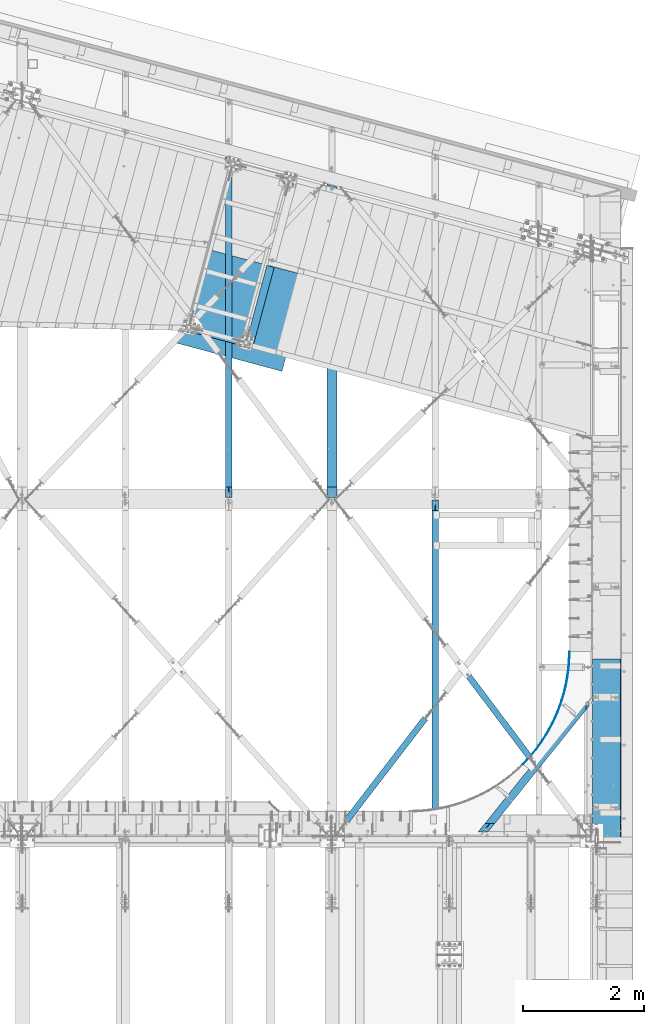
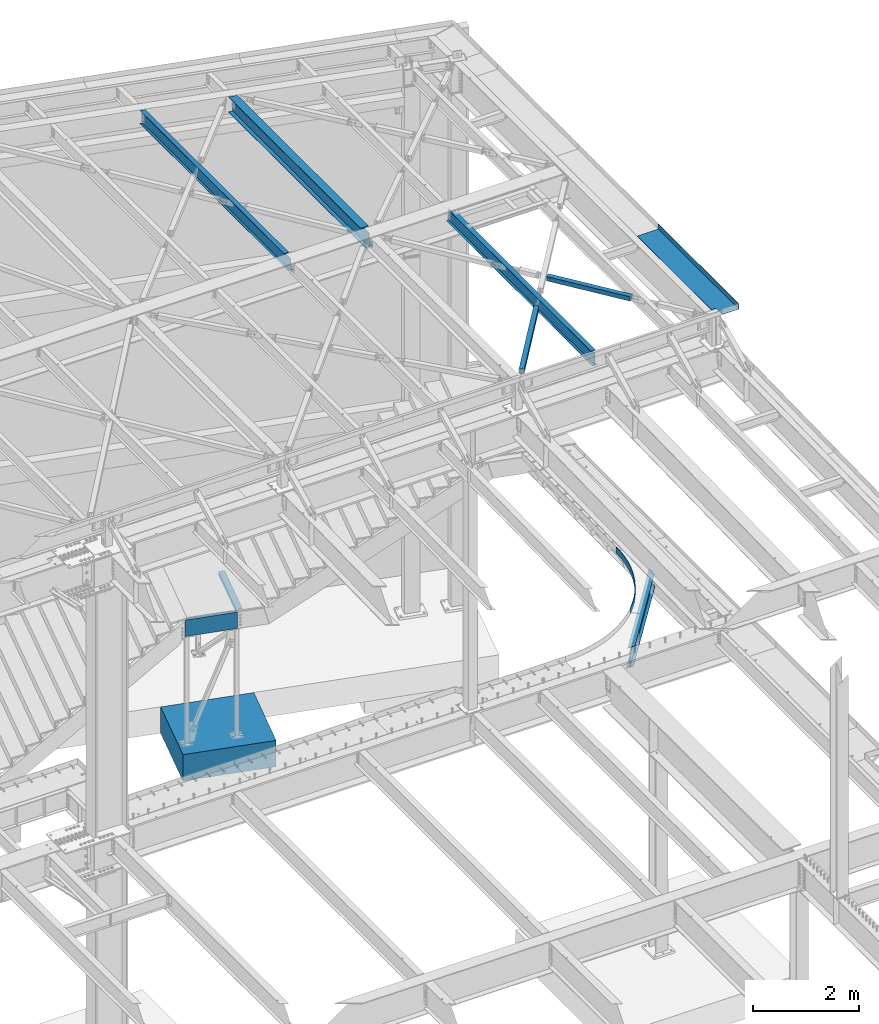
# One storey, part 1168 of 1763: 11 beams, 9 elements without a shape of their own.
"""IFC2X3 building model written with IfcOpenShell, lengths in millimetres."""

from ifc_helpers import new_model, si_unit, frame, origin_with_axes, place, context, subcontext, project, spatial, faceted_brep, material, type_object, element, aggregate, save


model = new_model("IFC2X3")

# Units and contexts
model_context = context("Model", 3, precision=1e-05, world=origin_with_axes())
body_context = subcontext(model_context, "Body", "Model", "MODEL_VIEW")
ifc_project = project(units=[si_unit("LENGTHUNIT", "METRE", prefix="MILLI"), si_unit("AREAUNIT", "SQUARE_METRE"), si_unit("VOLUMEUNIT", "CUBIC_METRE"), si_unit("MASSUNIT", "GRAM", prefix="KILO"), si_unit("TIMEUNIT", "SECOND"), si_unit("PLANEANGLEUNIT", "RADIAN"), si_unit("SOLIDANGLEUNIT", "STERADIAN"), si_unit("THERMODYNAMICTEMPERATUREUNIT", "DEGREE_CELSIUS"), si_unit("LUMINOUSINTENSITYUNIT", "LUMEN")], contexts=[model_context])

# Site, building, storey
site_placement = place(None, origin_with_axes())
site = spatial("IfcSite", under=ifc_project, at=site_placement, CompositionType="ELEMENT")
building_placement = place(site_placement, origin_with_axes())
building = spatial("IfcBuilding", under=site, at=building_placement, Name="Undefined", CompositionType="ELEMENT")
storey_placement = place(building_placement, origin_with_axes())
storey = spatial("IfcBuildingStorey", under=building, at=storey_placement, Name="Undefined", CompositionType="ELEMENT", Elevation=0.0)

# Assembly, beam
assembly_1_placement = place(storey_placement, origin_with_axes())
assembly_1 = element("IfcElementAssembly", 1, at=assembly_1_placement, inside=storey, Name="FRAME", AssemblyPlace="NOTDEFINED", PredefinedType="RIGID_FRAME")
ifc_material_1 = material(Name="STEEL/A36")
beam_type_1 = type_object("IfcBeamType", Name="L5X3X1/4", PredefinedType="NOTDEFINED")
beam_1_placement = place(assembly_1_placement, frame((-27333.7089547892, 60296.3078394912, 2590.8), z_axis=(0.965912656072286, -0.258868192019377, 0.0), x_axis=(0.258868192019374, 0.965912656072287, 0.0)))
beam_1 = element("IfcBeam", 2, at=beam_1_placement, type_object=beam_type_1, material=ifc_material_1, Name="ANGLE", ObjectType="L5X3X1/4", context=body_context, shape_type="Brep", body=[
    faceted_brep([(2.03726813197136e-10, 38.0999999999999, -63.5000000001164), (-2.03726813197136e-10, 38.0999999999999, 63.5000000001164), (1302.58050386085, 38.0999999999999, 63.5000000013679), (1302.58050386054, 38.0999999999999, -63.4999999986103), (-2.03726813197136e-10, 31.75, 63.5000000001164), (1302.58050386085, 31.75, 63.5000000013679), (1.81898940354586e-10, 31.75, -57.1500000001106), (1302.58050386055, 31.75, -57.1499999986117), (1.81898940354586e-10, -38.0999999999999, -57.1500000001106), (1302.58050386055, -38.0999999999999, -57.1499999986117), (2.03726813197136e-10, -38.0999999999999, -63.5000000001164), (1302.58050386054, -38.0999999999999, -63.4999999986103)], [[[0, 1, 2, 3]], [[1, 4, 5, 2]], [[4, 6, 7, 5]], [[6, 8, 9, 7]], [[8, 10, 11, 9]], [[10, 0, 3, 11]], [[5, 7, 9, 11, 3, 2]], [[10, 8, 6, 4, 1, 0]]]),
])

assembly_2_placement = place(storey_placement, origin_with_axes())
assembly_2 = element("IfcElementAssembly", 3, at=assembly_2_placement, inside=storey, Name="BEAM", AssemblyPlace="NOTDEFINED", PredefinedType="RIGID_FRAME")
beam_type_2 = type_object("IfcBeamType", PredefinedType="NOTDEFINED")
beam_2_placement = place(assembly_2_placement, frame((-22813.2239876411, 53302.7560028055, 5245.1), z_axis=(0.0, 0.0, 1.0), x_axis=(0.38198610405508, 0.924168067133258, 0.0)))
beam_2 = element("IfcBeam", 4, at=beam_2_placement, type_object=beam_type_2, material=ifc_material_1, Name="PLATE", context=body_context, shape_type="Brep", body=[
    faceted_brep([(1.81687949722254, 4.40231247671181, -76.1999999999998), (1.81687949722254, 4.40231247671181, 76.1999999999998), (98.140663038459, -33.1626768406859, 76.1999999999998), (98.140663038459, -33.1626768406859, -76.1999999999998), (-1.81687949721527, -4.40231247670454, 76.1999999999998), (-1.81687949721527, -4.40231247670454, -76.1999999999998), (94.8542257076115, -42.1027526049293, -76.1999999999998), (94.8542257076115, -42.1027526049293, 76.1999999999998), (195.860644678804, -66.9295968412698, 76.1999999999998), (195.860644678804, -66.9295968412698, -76.1999999999998), (192.926563384462, -75.9914284418919, -76.1999999999998), (192.926563384462, -75.9914284418919, 76.1999999999998), (294.827130759491, -96.8467212177347, 76.1999999999998), (294.827130759491, -96.8467212177347, -76.1999999999998), (292.249900113253, -106.016427166993, -76.1999999999998), (292.249900113253, -106.016427166993, 76.1999999999998), (394.88851814728, -122.868221023593, 76.1999999999998), (394.88851814728, -122.868221023593, -76.1999999999998), (392.672086114333, -132.131754584996, -76.1999999999998), (392.672086114333, -132.131754584996, 76.1999999999998), (495.891526469735, -144.954234876917, 76.1999999999998), (495.891526469735, -144.954234876917, -76.1999999999998), (494.039288321081, -154.297405582867, -76.1999999999998), (494.039288321081, -154.297405582867, 76.1999999999998), (597.681432919831, -163.070930022448, 76.1999999999998), (597.681432919831, -163.070930022448, -76.1999999999998), (596.196226031221, -172.479425412144, -76.1999999999998), (596.196226031221, -172.479425412144, 76.1999999999998), (700.102309270136, -177.190554158813, 76.1999999999998), (700.102309270136, -177.190554158813, -76.1999999999998), (698.986408775563, -186.649961702948, -76.1999999999998), (698.986408775563, -186.649961702948, 76.1999999999998), (802.997260733529, -187.291477951236, 76.1999999999998), (802.997260733529, -187.291477951236, -76.1999999999998), (802.252376040065, -196.787307130056, -76.1999999999998), (802.252376040065, -196.787307130056, 76.1999999999998), (906.208666304636, -193.35822816471, 76.1999999999998), (906.208666304636, -193.35822816471, -76.1999999999998), (905.835938473858, -202.875932665484, -76.1999999999998), (905.835938473858, -202.875932665484, 76.1999999999998), (1009.57842021359, -195.381511366933, 76.1999999999998), (1009.57842021359, -195.381511366933, -76.1999999999998), (1009.5784202136, -204.90651136692, -76.1999999999998), (1009.5784202136, -204.90651136692, 76.1999999999998), (1112.94817412255, -193.358228164492, 76.1999999999998), (1112.94817412255, -193.358228164492, -76.1999999999998), (1113.32090195334, -202.875932665265, -76.1999999999998), (1113.32090195334, -202.875932665265, 76.1999999999998), (1216.15957969364, -187.291477950785, 76.1999999999998), (1216.15957969364, -187.291477950785, -76.1999999999998), (1216.90446438711, -196.787307129605, -76.1999999999998), (1216.90446438711, -196.787307129605, 76.1999999999998), (1319.05453115702, -177.190554158144, 76.1999999999998), (1319.05453115702, -177.190554158144, -76.1999999999998), (1320.17043165161, -186.649961702278, -76.1999999999998), (1320.17043165161, -186.649961702278, 76.1999999999998), (1421.47540750729, -163.070930021553, 76.1999999999998), (1421.47540750729, -163.070930021553, -76.1999999999998), (1422.96061439592, -172.479425411242, -76.1999999999998), (1422.96061439592, -172.479425411242, 76.1999999999998), (1523.26531395734, -144.954234875797, 76.1999999999998), (1523.26531395734, -144.954234875797, -76.1999999999998), (1525.11755210601, -154.297405581747, -76.1999999999998), (1525.11755210601, -154.297405581747, 76.1999999999998), (1624.26832227975, -122.868221022261, 76.1999999999998), (1624.26832227975, -122.868221022261, -76.1999999999998), (1626.48475431271, -132.13175458365, -76.1999999999998), (1626.48475431271, -132.13175458365, 76.1999999999998), (1724.32970966748, -96.8467212161777, 76.1999999999998), (1724.32970966748, -96.8467212161777, -76.1999999999998), (1726.90694031374, -106.016427165436, -76.1999999999998), (1726.90694031374, -106.016427165436, 76.1999999999998), (1823.29619574809, -66.9295968394945, 76.1999999999998), (1823.29619574809, -66.9295968394945, -76.1999999999998), (1826.23027704246, -75.9914284401166, -76.1999999999998), (1826.23027704246, -75.9914284401166, 76.1999999999998), (1921.01617738837, -33.1626768387068, 76.1999999999998), (1921.01617738837, -33.1626768387068, -76.1999999999998), (1924.30261471924, -42.1027526029357, -76.1999999999998), (1924.30261471924, -42.1027526029357, 76.1999999999998), (2017.33996092953, 4.40231247890915, 76.1999999999998), (2017.33996092953, 4.40231247890915, -76.1999999999998), (2020.97371992398, -4.40231247449992, 76.1999999999998), (2020.97371992398, -4.40231247449992, -76.1999999999998)], [[[0, 1, 2, 3]], [[4, 5, 6, 7]], [[5, 4, 1, 0]], [[3, 2, 8, 9]], [[7, 6, 10, 11]], [[9, 8, 12, 13]], [[11, 10, 14, 15]], [[13, 12, 16, 17]], [[15, 14, 18, 19]], [[17, 16, 20, 21]], [[19, 18, 22, 23]], [[21, 20, 24, 25]], [[23, 22, 26, 27]], [[25, 24, 28, 29]], [[27, 26, 30, 31]], [[29, 28, 32, 33]], [[31, 30, 34, 35]], [[33, 32, 36, 37]], [[35, 34, 38, 39]], [[37, 36, 40, 41]], [[39, 38, 42, 43]], [[41, 40, 44, 45]], [[43, 42, 46, 47]], [[45, 44, 48, 49]], [[47, 46, 50, 51]], [[49, 48, 52, 53]], [[51, 50, 54, 55]], [[53, 52, 56, 57]], [[55, 54, 58, 59]], [[57, 56, 60, 61]], [[59, 58, 62, 63]], [[61, 60, 64, 65]], [[63, 62, 66, 67]], [[65, 64, 68, 69]], [[67, 66, 70, 71]], [[69, 68, 72, 73]], [[71, 70, 74, 75]], [[73, 72, 76, 77]], [[75, 74, 78, 79]], [[77, 76, 80, 81]], [[76, 72, 68, 64, 60, 56, 52, 48, 44, 40, 36, 32, 28, 24, 20, 16, 12, 8, 2, 1, 4, 7, 11, 15, 19, 23, 27, 31, 35, 39, 43, 47, 51, 55, 59, 63, 67, 71, 75, 79, 82, 80]], [[79, 78, 83, 82]], [[78, 74, 70, 66, 62, 58, 54, 50, 46, 42, 38, 34, 30, 26, 22, 18, 14, 10, 6, 5, 0, 3, 9, 13, 17, 21, 25, 29, 33, 37, 41, 45, 49, 53, 57, 61, 65, 69, 73, 77, 81, 83]], [[82, 83, 81, 80]]]),
])

assembly_3_placement = place(storey_placement, origin_with_axes())
assembly_3 = element("IfcElementAssembly", 5, at=assembly_3_placement, inside=storey, Name="BEAM", AssemblyPlace="NOTDEFINED", PredefinedType="RIGID_FRAME")
ifc_material_2 = material(Name="STEEL/A992")
beam_type_3 = type_object("IfcBeamType", Name="W14X30", PredefinedType="NOTDEFINED")
beam_3_placement = place(assembly_3_placement, frame((-25976.6096174479, 57702.4500000004, 12269.7875), z_axis=(0.0, 0.0, 1.0), x_axis=(0.0, 1.0, 0.0)))
beam_3 = element("IfcBeam", 6, at=beam_3_placement, type_object=beam_type_3, material=ifc_material_2, Name="BEAM", ObjectType="W14X30", context=body_context, shape_type="Brep", body=[
    faceted_brep([(179.387500190307, -3.17499999999927, 137.852501678466), (179.387500190307, 3.17499999999927, 137.852501678466), (20.6374999995751, 3.17499999999927, 137.852501678466), (20.6374999995751, -3.17499999999927, 137.852501678466), (184.247579708353, -3.17499999999927, 138.819231601054), (184.247579708353, 3.17499999999927, 138.819231601054), (188.367756176507, -3.17499999999927, 141.572245501531), (188.367756176507, 3.17499999999927, 141.572245501531), (191.120770076981, -3.17499999999927, 145.692421969685), (191.120770076981, 3.17499999999927, 145.692421969685), (192.087499999572, -3.17499999999927, 150.552501487731), (192.087499999572, 3.17499999999927, 150.552501487731), (192.087499999572, -85.7249999999985, 176.2125), (192.087499999572, 85.7249999999985, 176.2125), (192.087499999572, 85.7249999999985, 166.6875), (192.087499999572, 3.17499999999927, 166.6875), (192.087499999572, -3.17499999999927, 166.6875), (192.087499999572, -85.7249999999985, 166.6875), (20.6374999995751, -3.17499999999927, -166.6875), (20.6374999995751, -85.7249999999985, -166.6875), (5167.90416276084, -85.7249999999985, -166.6875), (5190.02336859389, -3.17499999999927, -166.6875), (20.6374999995751, -85.7249999999985, -176.2125), (5167.90416276084, -85.7249999999985, -176.2125), (20.6374999995751, 85.7249999999985, -176.2125), (5213.84405179871, 85.7249999999985, -176.2125), (20.6374999995751, 85.7249999999985, -166.6875), (20.6374999995751, 3.17499999999927, -166.6875), (5191.72484596566, 3.17499999999927, -166.6875), (5213.84405179871, 85.7249999999985, -166.6875), (5191.72484596566, 3.17499999999927, 166.6875), (5213.84405179871, 85.7249999999985, 166.6875), (5213.84405179871, 85.7249999999985, 176.2125), (5167.90416276084, -85.7249999999985, 176.2125), (5167.90416276084, -85.7249999999985, 166.6875), (5190.02336859389, -3.17499999999927, 166.6875)], [[[0, 1, 2, 3]], [[4, 5, 1, 0]], [[6, 7, 5, 4]], [[8, 9, 7, 6]], [[10, 11, 9, 8]], [[12, 13, 14, 15, 11, 10, 16, 17]], [[18, 19, 20, 21]], [[19, 22, 23, 20]], [[22, 24, 25, 23]], [[26, 27, 28, 29]], [[24, 26, 29, 25]], [[28, 30, 31, 32, 33, 34, 35, 21, 20, 23, 25, 29]], [[34, 33, 12, 17]], [[35, 34, 17, 16]], [[8, 6, 4, 0, 3, 18, 21, 35, 16, 10]], [[27, 26, 24, 22, 19, 18, 3, 2]], [[30, 28, 27, 2, 1, 5, 7, 9, 11, 15]], [[31, 30, 15, 14]], [[32, 31, 14, 13]], [[33, 32, 13, 12]]]),
])
aggregate(assembly_3, [beam_3])

assembly_4_placement = place(storey_placement, origin_with_axes())
assembly_4 = element("IfcElementAssembly", 7, at=assembly_4_placement, inside=storey, Name="H. BRACE", AssemblyPlace="NOTDEFINED", PredefinedType="RIGID_FRAME")
ifc_material_3 = material()
beam_type_4 = type_object("IfcBeamType", Name="HSS4X4X3/8", PredefinedType="NOTDEFINED")
beam_4_placement = place(assembly_4_placement, frame((-22546.3296174484, 53216.5500898741, 12371.3875), z_axis=(-0.798711499075791, -0.601714169057122, 0.0), x_axis=(-0.601714169057124, 0.798711499075789, 0.0)))
beam_4 = element("IfcBeam", 8, at=beam_4_placement, type_object=beam_type_4, material=ifc_material_3, Name="H. BRACE", ObjectType="HSS4X4X3/8", context=body_context, shape_type="Brep", body=[
    faceted_brep([(2005.41376927734, 6.35000000000218, 50.8000000003503), (1931.32239554346, 6.35000000000218, 50.8000000003321), (1931.3223955434, 6.35000000000218, 41.2750000003598), (2005.41376927731, 6.35000000000218, 41.2750000003707), (1931.32239554346, -6.34999999999854, 50.8000000003321), (1931.3223955434, -6.34999999999854, 41.2750000003598), (2005.41376927734, -6.34999999999854, 50.8000000003503), (2005.41376927731, -6.34999999999854, 41.2750000003707), (2005.41376927707, 6.35000000000218, -41.2749999994394), (1931.32239554294, 6.35000000000218, -41.2749999994539), (1931.32239554289, 6.35000000000218, -50.7999999994336), (2005.41376927704, 6.35000000000218, -50.7999999994154), (1931.32239554294, -6.34999999999854, -41.2749999994539), (1931.32239554289, -6.34999999999854, -50.7999999994336), (2005.41376927707, -6.34999999999854, -41.2749999994394), (2005.41376927704, -6.34999999999854, -50.7999999994154), (281.529879994778, 41.2749999999996, 41.2749999999724), (281.529879994538, 41.2749999999996, -41.2749999998341), (2005.41376927707, 41.2749999999996, -41.2749999994394), (2005.41376927731, 41.2749999999996, 41.2750000003707), (2005.41376927731, -41.2749999999996, 41.2750000003707), (281.529879994778, -41.2749999999996, 41.2749999999724), (281.529879994538, -41.2749999999996, -41.2749999998341), (2005.41376927707, -41.2749999999996, -41.2749999994394), (281.529879994509, -50.7999999999993, -50.7999999998101), (281.529879994807, -50.7999999999993, 50.7999999999593), (281.529879994807, 50.7999999999993, 50.7999999999593), (281.529879994509, 50.7999999999993, -50.7999999998101), (2005.41376927734, 50.7999999999993, 50.8000000003503), (2005.41376927704, 50.7999999999993, -50.7999999994154), (2005.41376927704, -50.7999999999993, -50.7999999994154), (2005.41376927734, -50.7999999999993, 50.8000000003503)], [[[0, 1, 2, 3]], [[4, 5, 2, 1]], [[6, 7, 5, 4]], [[8, 9, 10, 11]], [[12, 13, 10, 9]], [[14, 15, 13, 12]], [[16, 17, 18, 19]], [[20, 21, 16, 19, 3, 2, 5, 7]], [[22, 21, 20, 23]], [[9, 8, 18, 17, 22, 23, 14, 12]], [[24, 25, 26, 27], [16, 21, 22, 17]], [[27, 26, 28, 29]], [[19, 18, 8, 11, 29, 28, 0, 3]], [[30, 24, 27, 29, 11, 10, 13, 15]], [[25, 24, 30, 31]], [[1, 0, 28, 26, 25, 31, 6, 4]], [[31, 30, 15, 14, 23, 20, 7, 6]]]),
])
aggregate(assembly_4, [beam_4])

assembly_5_placement = place(storey_placement, origin_with_axes())
assembly_5 = element("IfcElementAssembly", 9, at=assembly_5_placement, inside=storey, Name="H. BRACE", AssemblyPlace="NOTDEFINED", PredefinedType="RIGID_FRAME")
beam_5_placement = place(assembly_5_placement, frame((-25925.80961641, 52120.8000005081, 12371.3875), z_axis=(0.0, 0.0, 1.0), x_axis=(0.609825086268862, 0.792536033349383, 0.0)))
beam_5 = element("IfcBeam", 10, at=beam_5_placement, type_object=beam_type_4, material=ifc_material_3, Name="H. BRACE", ObjectType="HSS4X4X3/8", context=body_context, shape_type="Brep", body=[
    faceted_brep([(317.876285807837, 41.2749999990847, -41.2749999999996), (317.876285808015, -41.2750000010492, -41.2749999999996), (2442.64763338234, -41.2750000076412, -41.2749999999996), (2442.64763338215, 41.2749999924927, -41.2749999999996), (317.876285808015, -41.2750000010492, 41.2749999999996), (2442.64763338234, -41.2750000076412, 41.2749999999996), (317.876285807837, 41.2749999990847, 41.2749999999996), (2442.64763338215, 41.2749999924927, 41.2749999999996), (317.876285807812, 50.799999999108, -50.7999999999993), (317.876285807812, 50.799999999108, 50.7999999999993), (2442.64763338213, 50.7999999925014, 50.7999999999993), (2442.64763338213, 50.7999999925014, -50.7999999999993), (317.876285808037, -50.8000000010652, 50.7999999999993), (2442.64763338235, -50.8000000076645, 50.7999999999993), (317.876285808037, -50.8000000010652, -50.7999999999993), (2442.64763338235, -50.8000000076645, -50.7999999999993)], [[[0, 1, 2, 3]], [[1, 4, 5, 2]], [[4, 6, 7, 5]], [[6, 0, 3, 7]], [[8, 9, 10, 11]], [[9, 12, 13, 10]], [[12, 14, 15, 13]], [[14, 8, 11, 15]], [[13, 15, 11, 10], [5, 7, 3, 2]], [[14, 12, 9, 8], [6, 4, 1, 0]]]),
])
aggregate(assembly_5, [beam_5])

# Beam
beam_type_5 = type_object("IfcBeamType", Name="W14X22", PredefinedType="NOTDEFINED")
beam_6_placement = place(assembly_2_placement, frame((-23521.3534441522, 52120.8, 5019.675), z_axis=(0.0, 0.0, 1.0), x_axis=(0.626573581392241, 0.779362269487881, 0.0)))
beam_6 = element("IfcBeam", 11, at=beam_6_placement, type_object=beam_type_5, material=ifc_material_2, Name="BEAM", ObjectType="W14X22", context=body_context, shape_type="Brep", body=[
    faceted_brep([(246.983183446751, -3.1750000003376, 104.775000001958), (241.878057887534, 3.17499999968277, 104.775000001958), (75.8689266779074, 3.17499999990105, 104.77500000184), (80.9740522371176, -3.17500000011205, 104.77500000184), (253.219153172682, -3.1750000003376, 105.741729924549), (248.114027613465, 3.17499999968277, 105.741729924549), (258.50575303705, -3.17500000034488, 108.494743825028), (253.400627477837, 3.17499999966822, 108.494743825028), (262.038146133647, -3.17500000035216, 112.61492029318), (256.93302057443, 3.17499999966822, 112.61492029318), (263.278557634738, -3.17500000035216, 117.474999811223), (258.173432075524, 3.17499999966822, 117.474999811223), (311.777250447274, -63.5000000004948, 174.625), (209.674739262988, 63.4999999998035, 174.625), (209.674739262988, 63.4999999998035, 166.6875), (258.173432075524, 3.17499999966822, 166.6875), (263.278557634738, -3.17500000035216, 166.6875), (311.777250447274, -63.5000000004948, 166.6875), (80.9740522371176, -3.17500000011205, -166.6875), (129.472745049654, -63.5000000002547, -166.6875), (2797.13648107973, -63.5000000037326, -166.6875), (2872.17160912068, -3.17500000375003, -166.6875), (129.472745049654, -63.5000000002547, -174.625), (2797.13648107973, -63.5000000037326, -174.625), (27.3702338653675, 63.5000000000437, -174.625), (2955.10517169224, 63.4999999962238, -174.625), (27.3702338653675, 63.5000000000437, -166.6875), (2955.10517169224, 63.4999999962238, -166.6875), (75.8689266779074, 3.17499999990105, -166.6875), (2880.0700436513, 3.17499999624852, -166.6875), (2880.0700436513, 3.17499999624852, 138.112499999998), (2872.17160912068, -3.17500000375003, 138.112499999998), (2826.86400436265, 3.17499999630672, 138.112499999998), (2818.96556983202, -3.17500000368454, 138.112499999998), (2819.10740615553, 3.17499999632855, 139.079229922586), (2811.20897162491, -3.17500000366999, 139.079229922586), (2812.53167971172, 3.17499999633583, 141.832243823064), (2804.63324518109, -3.17500000366272, 141.832243823064), (2808.13791977315, 3.1749999963431, 145.952420291218), (2800.23948524253, -3.17500000365544, 145.952420291218), (2806.59503646096, 3.1749999963431, 150.812499809263), (2798.69660193034, -3.17500000365544, 150.812499809263), (2881.63016450191, 63.4999999963184, 174.625), (2723.66147388939, -63.500000003638, 174.625), (2723.66147388939, -63.500000003638, 166.6875), (2798.69660193034, -3.17500000365544, 166.6875), (2806.59503646096, 3.1749999963431, 166.6875), (2881.63016450191, 63.4999999963184, 166.6875)], [[[0, 1, 2, 3]], [[4, 5, 1, 0]], [[6, 7, 5, 4]], [[8, 9, 7, 6]], [[10, 11, 9, 8]], [[12, 13, 14, 15, 11, 10, 16, 17]], [[18, 19, 20, 21]], [[19, 22, 23, 20]], [[22, 24, 25, 23]], [[24, 26, 27, 25]], [[26, 28, 29, 27]], [[21, 20, 23, 25, 27, 29, 30, 31]], [[30, 32, 33, 31]], [[34, 35, 33, 32]], [[36, 37, 35, 34]], [[38, 39, 37, 36]], [[40, 41, 39, 38]], [[42, 43, 44, 45, 41, 40, 46, 47]], [[44, 43, 12, 17]], [[45, 44, 17, 16]], [[8, 6, 4, 0, 3, 18, 21, 31, 33, 35, 37, 39, 41, 45, 16, 10]], [[28, 26, 24, 22, 19, 18, 3, 2]], [[46, 40, 38, 36, 34, 32, 30, 29, 28, 2, 1, 5, 7, 9, 11, 15]], [[47, 46, 15, 14]], [[42, 47, 14, 13]], [[43, 42, 13, 12]]]),
])

aggregate(assembly_2, [beam_2, beam_6])

# Assembly, beam
assembly_6_placement = place(storey_placement, origin_with_axes())
assembly_6 = element("IfcElementAssembly", 12, at=assembly_6_placement, inside=storey, Name="BEAM", AssemblyPlace="NOTDEFINED", PredefinedType="RIGID_FRAME")
beam_type_6 = type_object("IfcBeamType", PredefinedType="NOTDEFINED")
beam_7_placement = place(assembly_6_placement, frame((-21657.3396174483, 53524.15, 12449.175), z_axis=(0.0, -1.0, 0.0), x_axis=(1.0, 0.0, 0.0)))
beam_7 = element("IfcBeam", 13, at=beam_7_placement, type_object=beam_type_6, material=ifc_material_1, Name="BENT_PLATE", context=body_context, shape_type="Brep", body=[
    faceted_brep([(101.599999809252, -3.17500000000655, 1289.05), (101.599999809252, 3.17499999999927, 1289.05), (0.0, 3.17499999999927, 1289.05), (0.0, -3.17499999999927, 1289.05), (101.599999809252, -3.17500000000655, 1524.0), (101.599999809252, 3.17499999999927, 1524.0), (466.725006103516, -3.17499999999927, -1524.0), (0.0, -3.17499999999927, -1523.99999999999), (0.0, 3.17499999999927, -1523.99999999999), (460.375006103517, 3.17499999999927, -1524.0), (460.375006103517, 123.825000000001, -1524.0), (466.725006103516, 123.825000000001, -1524.0), (460.375006103517, 3.17499999999927, 1524.0), (460.375006103517, 123.825000000001, 1524.0), (466.725006103516, 123.825000000001, 1524.0), (466.725006103516, -3.17499999999927, 1524.0)], [[[0, 1, 2, 3]], [[4, 5, 1, 0]], [[6, 7, 8, 9, 10, 11]], [[9, 12, 13, 10]], [[14, 11, 10, 13]], [[15, 6, 11, 14]], [[3, 7, 6, 15, 4, 0]], [[8, 7, 3, 2]], [[12, 9, 8, 2, 1, 5]], [[15, 14, 13, 12, 5, 4]]]),
])
aggregate(assembly_6, [beam_7])

# Beam
beam_type_7 = type_object("IfcBeamType", Name="C15X33.9", PredefinedType="NOTDEFINED")
beam_8_placement = place(assembly_1_placement, frame((-28411.5770444662, 60536.5385620884, 2438.4000000712), z_axis=(0.0, 0.0, -1.0), x_axis=(0.965913267114843, -0.258865912030785, 0.0)))
beam_8 = element("IfcBeam", 14, at=beam_8_placement, type_object=beam_type_7, material=ifc_material_1, Name="FRAME", ObjectType="C15X33.9", context=body_context, shape_type="Brep", body=[
    faceted_brep([(12.7259380533651, 42.8624999999884, -190.5), (12.7259380533651, 42.8624999999884, 190.5), (1039.83843805402, 42.8624999993408, 190.5), (1039.83843805402, 42.8624999993408, -190.5), (98.4509381102398, -42.8625000000611, 190.5), (954.113438110893, -42.8625000005995, 190.5), (98.4509381102398, -42.8625000000611, 181.7658925), (954.113438110893, -42.8625000005995, 181.7658925), (22.2509380596821, 33.3374999999796, 169.0709725), (1030.31343806034, 33.3374999993466, 169.0709725), (22.2509380596821, 33.3374999999796, -169.0709725), (1030.31343806034, 33.3374999993466, -169.0709725), (98.4509381102398, -42.8625000000611, -181.7658925), (954.113438110893, -42.8625000005995, -181.7658925), (98.4509381102398, -42.8625000000611, -190.5), (954.113438110893, -42.8625000005995, -190.5)], [[[0, 1, 2, 3]], [[1, 4, 5, 2]], [[4, 6, 7, 5]], [[6, 8, 9, 7]], [[8, 10, 11, 9]], [[10, 12, 13, 11]], [[12, 14, 15, 13]], [[14, 0, 3, 15]], [[5, 7, 9, 11, 13, 15, 3, 2]], [[14, 12, 10, 8, 6, 4, 1, 0]]]),
])

aggregate(assembly_1, [beam_1, beam_8])

# Assembly, beam
assembly_7_placement = place(storey_placement, origin_with_axes())
assembly_7 = element("IfcElementAssembly", 15, at=assembly_7_placement, inside=storey, Name="BEAM", AssemblyPlace="NOTDEFINED", PredefinedType="RIGID_FRAME")
beam_type_8 = type_object("IfcBeamType", Name="W12X16", PredefinedType="NOTDEFINED")
beam_9_placement = place(assembly_7_placement, frame((-27688.5696174484, 57702.45, 12293.6), z_axis=(0.0, 0.0, 1.0), x_axis=(0.0, 1.0, 0.0)))
beam_9 = element("IfcBeam", 16, at=beam_9_placement, type_object=beam_type_8, material=ifc_material_2, Name="BEAM", ObjectType="W12X16", context=body_context, shape_type="Brep", body=[
    faceted_brep([(20.637499999335, -3.17500000023574, -146.050000000019), (20.637499999335, -50.8000000002503, -146.05000000003), (5635.98058772866, -50.7999999999993, -146.049999999999), (5648.74166801695, -3.17499999999927, -146.049999999999), (20.637499999335, -50.8000000002576, -152.400000000032), (5635.98058772866, -50.7999999999993, -152.4), (20.637499999335, 50.7999999997701, -152.400000000003), (5663.20422567702, 50.7999999999993, -152.4), (20.637499999335, 50.7999999997774, -146.050000000005), (5663.20422567702, 50.7999999999993, -146.049999999999), (5650.44314538872, 3.17499999999927, -146.049999999999), (5650.44314538872, 3.17499999999927, 146.049999999999), (5663.20422567702, 50.7999999999993, 146.049999999999), (5663.20422567702, 50.7999999999993, 152.4), (5635.98058772866, -50.7999999999993, 152.4), (5635.98058772866, -50.7999999999993, 146.049999999999), (5648.74166801695, -3.17499999999927, 146.049999999999), (20.637499999335, 3.17499999977008, -146.050000000016), (184.247579708775, -3.17500000000291, 115.006731601054), (184.247579708775, 3.17500000000291, 115.006731601054), (179.387500190729, 3.17500000000291, 114.040001678466), (179.387500190729, -3.17500000000291, 114.040001678466), (188.367756176929, -3.17500000000291, 117.759745501531), (188.367756176929, 3.17500000000291, 117.759745501531), (191.120770077403, -3.17500000000291, 121.879921969685), (191.120770077403, 3.17500000000291, 121.879921969685), (192.087499999994, -3.17500000000291, 126.740001487731), (192.087499999994, 3.17500000000291, 126.740001487731), (20.6374999999971, 3.17500000000291, 114.040001678466), (192.087499999994, 3.17500000000291, 146.049999999999), (192.087499999994, 50.8000000000029, 146.049999999999), (192.087499999994, 50.8000000000029, 152.4), (192.087499999994, -50.8000000000029, 152.4), (192.087499999994, -50.8000000000029, 146.049999999999), (192.087499999994, -3.17500000000291, 146.049999999999), (20.6374999999971, -3.17500000000291, 114.040001678466)], [[[0, 1, 2, 3]], [[1, 4, 5, 2]], [[4, 6, 7, 5]], [[6, 8, 9, 7]], [[10, 11, 12, 13, 14, 15, 16, 3, 2, 5, 7, 9]], [[8, 17, 10, 9]], [[18, 19, 20, 21]], [[22, 23, 19, 18]], [[24, 25, 23, 22]], [[26, 27, 25, 24]], [[11, 10, 17, 28, 20, 19, 23, 25, 27, 29]], [[12, 11, 29, 30]], [[13, 12, 30, 31]], [[14, 13, 31, 32]], [[15, 14, 32, 33]], [[16, 15, 33, 34]], [[32, 31, 30, 29, 27, 26, 34, 33]], [[24, 22, 18, 21, 35, 0, 3, 16, 34, 26]], [[17, 8, 6, 4, 1, 0, 35, 28]], [[21, 20, 28, 35]]]),
])
aggregate(assembly_7, [beam_9])

assembly_8_placement = place(storey_placement, origin_with_axes())
assembly_8 = element("IfcElementAssembly", 17, at=assembly_8_placement, inside=storey, Name="BEAM", AssemblyPlace="NOTDEFINED", PredefinedType="RIGID_FRAME")
beam_10_placement = place(assembly_8_placement, frame((-24264.6496174484, 52120.8, 12293.6), z_axis=(0.0, 0.0, 1.0), x_axis=(0.0, 1.0, 0.0)))
beam_10 = element("IfcBeam", 18, at=beam_10_placement, type_object=beam_type_8, material=ifc_material_2, Name="BEAM", ObjectType="W12X16", context=body_context, shape_type="Brep", body=[
    faceted_brep([(63.5000001907174, -3.17499999999927, 126.740001678467), (63.5000001907174, 3.17499999999927, 126.740001678467), (15.8749999999854, 3.17499999999927, 126.740001678467), (15.8749999999854, -3.17499999999927, 126.740001678467), (68.3600797087638, -3.17499999999927, 127.706731601054), (68.3600797087638, 3.17499999999927, 127.706731601054), (72.4802561769175, -3.17499999999927, 130.459745501532), (72.4802561769175, 3.17499999999927, 130.459745501532), (75.2332700773914, -3.17499999999927, 134.579921969686), (75.2332700773914, 3.17499999999927, 134.579921969686), (76.1999999999825, -3.17499999999927, 139.440001487732), (76.1999999999825, 3.17499999999927, 139.440001487732), (76.1999999999825, -50.7999999999993, 152.4), (76.1999999999825, 50.7999999999993, 152.4), (76.1999999999825, 50.7999999999993, 146.049999999999), (76.1999999999825, 3.17499999999927, 146.049999999999), (76.1999999999825, -3.17499999999927, 146.049999999999), (76.1999999999825, -50.7999999999993, 146.049999999999), (15.8749999999854, -3.17499999999927, -146.049999999999), (15.8749999999854, -50.7999999999993, -146.049999999999), (5561.01249999999, -50.7999999999993, -146.049999999999), (5561.01249999999, -3.17499999999927, -146.049999999999), (15.8749999999854, -50.7999999999993, -152.4), (5561.01249999999, -50.7999999999993, -152.4), (15.8749999999854, 50.7999999999993, -152.4), (5561.01249999999, 50.7999999999993, -152.4), (15.8749999999854, 50.7999999999993, -146.049999999999), (5561.01249999999, 50.7999999999993, -146.049999999999), (15.8749999999854, 3.17499999999927, -146.049999999999), (5561.01249999999, 3.17499999999927, -146.049999999999), (5561.01249999999, 3.17499999999927, 114.040001678466), (5561.01249999999, -3.17499999999927, 114.040001678466), (5402.26249980926, 3.17499999999927, 114.040001678466), (5402.26249980926, -3.17499999999927, 114.040001678466), (5397.40242029121, 3.17499999999927, 115.006731601054), (5397.40242029121, -3.17499999999927, 115.006731601054), (5393.28224382306, 3.17499999999927, 117.759745501531), (5393.28224382306, -3.17499999999927, 117.759745501531), (5390.52922992258, 3.17499999999927, 121.879921969685), (5390.52922992258, -3.17499999999927, 121.879921969685), (5389.56249999999, 3.17499999999927, 126.740001487731), (5389.56249999999, -3.17499999999927, 126.740001487731), (5389.56249999999, -50.7999999999993, 152.4), (5389.56249999999, -50.7999999999993, 146.049999999999), (5389.56249999999, -3.17499999999927, 146.049999999999), (5389.56249999999, 3.17499999999927, 146.049999999999), (5389.56249999999, 50.7999999999993, 146.049999999999), (5389.56249999999, 50.7999999999993, 152.4)], [[[0, 1, 2, 3]], [[4, 5, 1, 0]], [[6, 7, 5, 4]], [[8, 9, 7, 6]], [[10, 11, 9, 8]], [[12, 13, 14, 15, 11, 10, 16, 17]], [[18, 19, 20, 21]], [[19, 22, 23, 20]], [[22, 24, 25, 23]], [[24, 26, 27, 25]], [[26, 28, 29, 27]], [[21, 20, 23, 25, 27, 29, 30, 31]], [[31, 30, 32, 33]], [[33, 32, 34, 35]], [[35, 34, 36, 37]], [[37, 36, 38, 39]], [[39, 38, 40, 41]], [[42, 43, 44, 41, 40, 45, 46, 47]], [[43, 42, 12, 17]], [[44, 43, 17, 16]], [[8, 6, 4, 0, 3, 18, 21, 31, 33, 35, 37, 39, 41, 44, 16, 10]], [[28, 26, 24, 22, 19, 18, 3, 2]], [[45, 40, 38, 36, 34, 32, 30, 29, 28, 2, 1, 5, 7, 9, 11, 15]], [[46, 45, 15, 14]], [[47, 46, 14, 13]], [[42, 47, 13, 12]]]),
])
aggregate(assembly_8, [beam_10])

assembly_9_placement = place(storey_placement, origin_with_axes())
assembly_9 = element("IfcElementAssembly", 19, at=assembly_9_placement, inside=storey, Name="FOOTING", AssemblyPlace="NOTDEFINED", PredefinedType="REINFORCEMENT_UNIT")
ifc_material_4 = material(Name="CONCRETE/3000")
beam_type_9 = type_object("IfcBeamType", PredefinedType="NOTDEFINED")
beam_11_placement = place(assembly_9_placement, frame((-27688.542412199, 60051.7768606826, -609.600000000005), z_axis=(0.0, 0.0, 1.0), x_axis=(0.258877132019957, 0.965910260074466, 0.0)))
beam_11 = element("IfcBeam", 20, at=beam_11_placement, type_object=beam_type_9, material=ifc_material_4, Name="FOOTING", context=body_context, shape_type="Brep", body=[
    faceted_brep([(2.21916707232594e-09, 914.400000000591, -304.8), (2.21916707232594e-09, 914.400000000591, 304.8), (1636.94353061381, 914.400000003923, 304.8), (1636.94353061381, 914.400000003923, -304.8), (-2.21189111471176e-09, -914.400000000569, 304.8), (1636.94353060937, -914.399999997244, 304.8), (-2.21189111471176e-09, -914.400000000569, -304.8), (1636.94353060937, -914.399999997244, -304.8)], [[[0, 1, 2, 3]], [[1, 4, 5, 2]], [[4, 6, 7, 5]], [[6, 0, 3, 7]], [[5, 7, 3, 2]], [[6, 4, 1, 0]]]),
])
aggregate(assembly_9, [beam_11])

save(model, "model.ifc")
